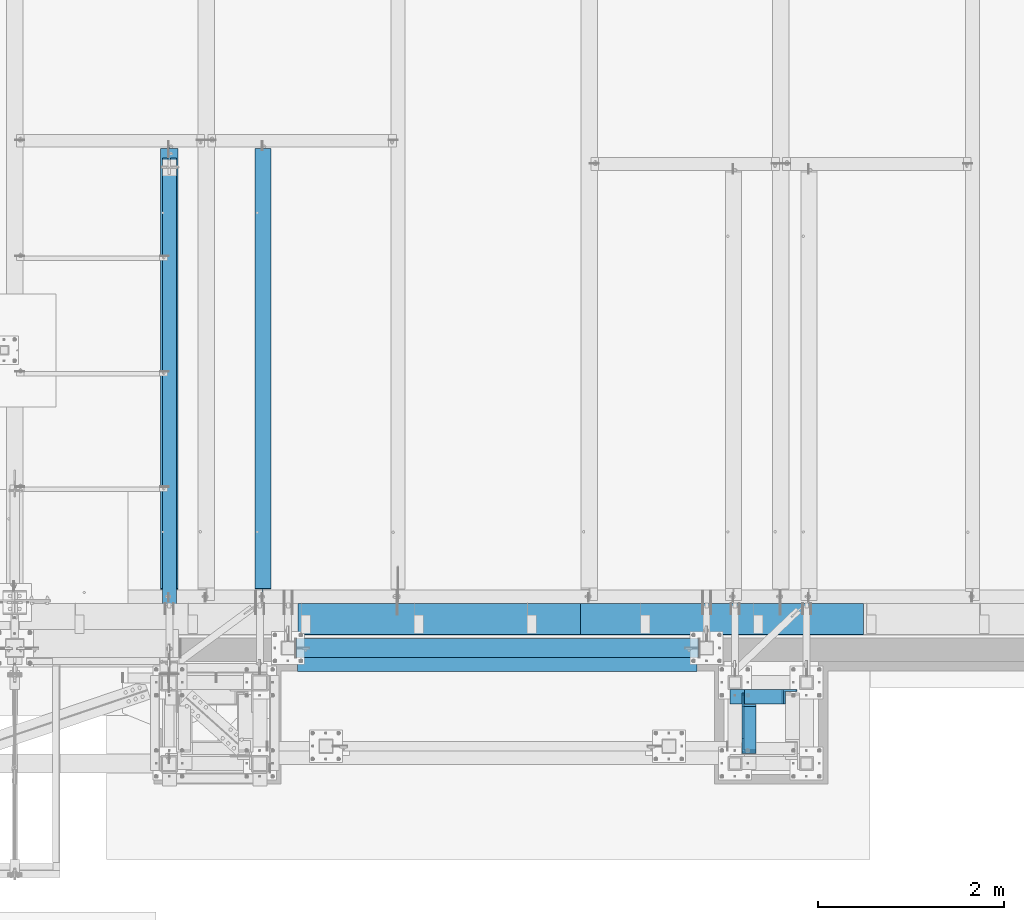
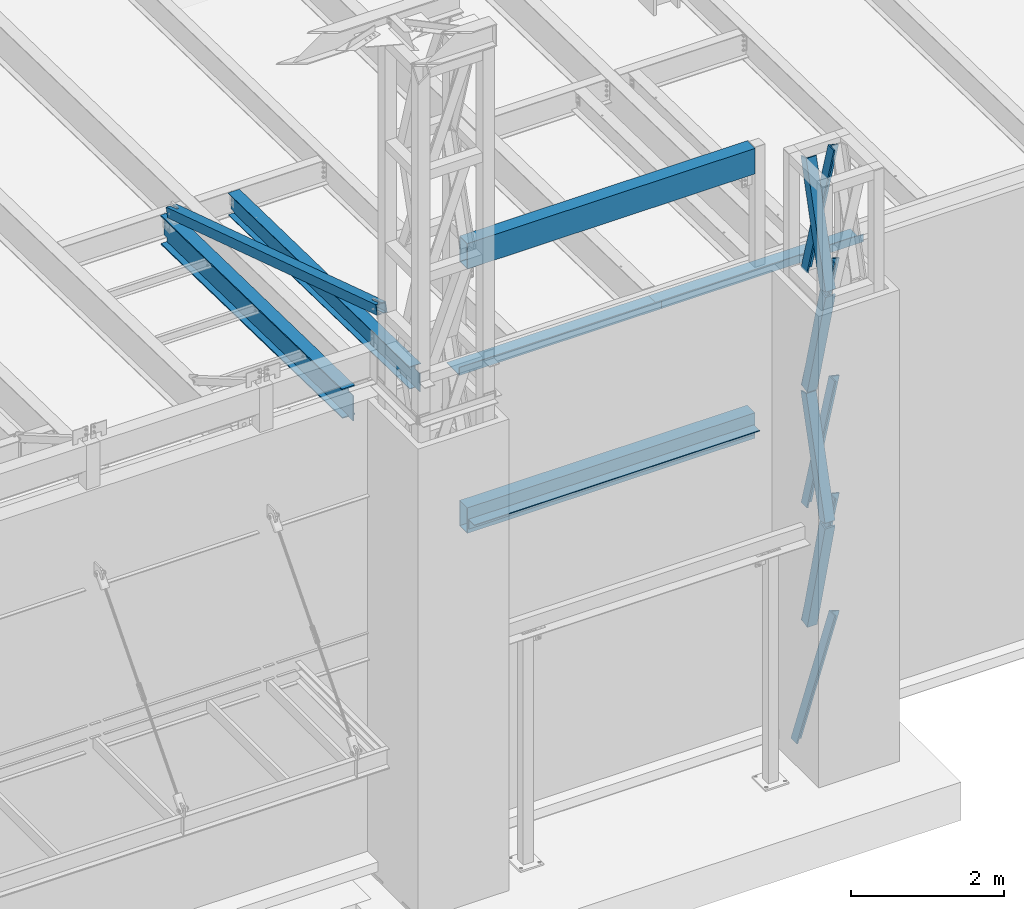
# One storey, part 1064 of 1763: 9 members, 8 beams, 7 elements without a shape of their own.
"""IFC2X3 building model written with IfcOpenShell, lengths in millimetres."""

from ifc_helpers import new_model, si_unit, frame, origin_with_axes, place, context, subcontext, project, spatial, faceted_brep, material, type_object, element, aggregate, save


model = new_model("IFC2X3")

# Units and contexts
model_context = context("Model", 3, precision=1e-05, world=origin_with_axes())
body_context = subcontext(model_context, "Body", "Model", "MODEL_VIEW")
ifc_project = project(units=[si_unit("LENGTHUNIT", "METRE", prefix="MILLI"), si_unit("AREAUNIT", "SQUARE_METRE"), si_unit("VOLUMEUNIT", "CUBIC_METRE"), si_unit("MASSUNIT", "GRAM", prefix="KILO"), si_unit("TIMEUNIT", "SECOND"), si_unit("PLANEANGLEUNIT", "RADIAN"), si_unit("SOLIDANGLEUNIT", "STERADIAN"), si_unit("THERMODYNAMICTEMPERATUREUNIT", "DEGREE_CELSIUS"), si_unit("LUMINOUSINTENSITYUNIT", "LUMEN")], contexts=[model_context])

# Site, building, storey
site_placement = place(None, origin_with_axes())
site = spatial("IfcSite", under=ifc_project, at=site_placement, CompositionType="ELEMENT")
building_placement = place(site_placement, origin_with_axes())
building = spatial("IfcBuilding", under=site, at=building_placement, Name="Undefined", CompositionType="ELEMENT")
storey_placement = place(building_placement, origin_with_axes())
storey = spatial("IfcBuildingStorey", under=building, at=storey_placement, Name="Undefined", CompositionType="ELEMENT", Elevation=0.0)

# Assembly, members
assembly_1_placement = place(storey_placement, origin_with_axes())
assembly_1 = element("IfcElementAssembly", 1, at=assembly_1_placement, inside=storey, Name="FRAME", AssemblyPlace="NOTDEFINED", PredefinedType="RIGID_FRAME")
ifc_material_1 = material(Name="STEEL/A36")
member_type = type_object("IfcMemberType", Name="L6X6X7/8", PredefinedType="NOTDEFINED")
member_1_placement = place(assembly_1_placement, frame((-41487.0960743807, -15268.1037197873, 12563.9140540722), z_axis=(0.0, 0.966292662023721, 0.25744609400632), x_axis=(0.0, 0.25744609400632, -0.966292662023721)))
member_1 = element("IfcMember", 2, at=member_1_placement, type_object=member_type, material=ifc_material_1, Name="V. BRACE", ObjectType="L6X6X7/8", context=body_context, shape_type="Brep", body=[
    faceted_brep([(9.09494701772928e-13, -76.2000000000007, -76.2000000000844), (9.09494701772928e-13, 76.2000000000007, -76.2000000000844), (1868.75344729561, 76.1999999999971, -76.1999999992731), (1868.75344729561, -76.1999999999971, -76.1999999992731), (1.81898940354586e-12, -76.2000000000007, -53.9750000000604), (1.81898940354586e-12, 53.9750000000004, -53.9750000000604), (0.0, 53.9750000000004, 76.2000000000771), (0.0, 76.2000000000007, 76.2000000000771), (1868.7534472956, -76.1999999999971, -53.9749999992673), (1868.7534472956, 53.9750000000058, -53.9749999992673), (1868.75344729555, 53.9750000000058, 76.2000000007865), (1868.75344729555, 76.1999999999971, 76.2000000007865)], [[[0, 1, 2, 3]], [[0, 4, 5, 6, 7, 1]], [[5, 4, 8, 9]], [[6, 5, 9, 10]], [[7, 6, 10, 11]], [[1, 7, 11, 2]], [[10, 9, 8, 3, 2, 11]], [[4, 0, 3, 8]]]),
])
member_2_placement = place(assembly_1_placement, frame((-41487.0960743773, -14763.9971201611, 14438.0001145442), z_axis=(0.0, 0.963857514375967, -0.266418265103921), x_axis=(0.0, -0.266418265103921, -0.963857514375967)))
member_2 = element("IfcMember", 3, at=member_2_placement, type_object=member_type, material=ifc_material_1, Name="V. BRACE", ObjectType="L6X6X7/8", context=body_context, shape_type="Brep", body=[
    faceted_brep([(9.09494701772928e-13, -76.2000000000007, -76.2000000000844), (9.09494701772928e-13, 76.2000000000007, -76.2000000000844), (1892.74960718638, 76.1999999999971, -76.2000000004191), (1892.74960718638, -76.1999999999971, -76.2000000004191), (1.81898940354586e-12, -76.2000000000007, -53.9750000000604), (1.81898940354586e-12, 53.9750000000004, -53.9750000000604), (0.0, 53.9750000000004, 76.2000000000771), (0.0, 76.2000000000007, 76.2000000000771), (1892.74960718638, -76.1999999999971, -53.9750000004096), (1892.74960718638, 53.9750000000058, -53.9750000004096), (1892.74960718641, 53.9750000000058, 76.1999999996406), (1892.74960718641, 76.1999999999971, 76.1999999996406)], [[[0, 1, 2, 3]], [[0, 4, 5, 6, 7, 1]], [[5, 4, 8, 9]], [[6, 5, 9, 10]], [[7, 6, 10, 11]], [[1, 7, 11, 2]], [[10, 9, 8, 3, 2, 11]], [[4, 0, 3, 8]]]),
])
member_3_placement = place(assembly_1_placement, frame((-41487.0960743875, -15255.7819813628, 8864.91422130301), z_axis=(0.0, 0.969515885272661, 0.24502846406891), x_axis=(0.0, 0.24502846406891, -0.969515885272661)))
member_3 = element("IfcMember", 4, at=member_3_placement, type_object=member_type, material=ifc_material_1, Name="V. BRACE", ObjectType="L6X6X7/8", context=body_context, shape_type="Brep", body=[
    faceted_brep([(9.09494701772928e-13, -76.2000000000007, -76.2000000000844), (9.09494701772928e-13, 76.2000000000007, -76.2000000000844), (1913.17175781412, 76.1999999999971, -76.1999999993586), (1913.17175781412, -76.1999999999971, -76.1999999993586), (1.81898940354586e-12, -76.2000000000007, -53.9750000000604), (1.81898940354586e-12, 53.9750000000004, -53.9750000000604), (0.0, 53.9750000000004, 76.2000000000771), (0.0, 76.2000000000007, 76.2000000000771), (1913.17175781411, -76.1999999999971, -53.9749999993746), (1913.17175781411, 53.9749999999985, -53.9749999993746), (1913.17175781408, 53.9749999999985, 76.2000000005337), (1913.17175781408, 76.1999999999971, 76.2000000005337)], [[[0, 1, 2, 3]], [[0, 4, 5, 6, 7, 1]], [[5, 4, 8, 9]], [[6, 5, 9, 10]], [[7, 6, 10, 11]], [[1, 7, 11, 2]], [[10, 9, 8, 3, 2, 11]], [[4, 0, 3, 8]]]),
])
member_4_placement = place(assembly_1_placement, frame((-41487.0960743841, -14763.9971201611, 10689.9126145442), z_axis=(0.0, 0.963857514375967, -0.266418265103921), x_axis=(0.0, -0.266418265103921, -0.963857514375967)))
member_4 = element("IfcMember", 5, at=member_4_placement, type_object=member_type, material=ifc_material_1, Name="V. BRACE", ObjectType="L6X6X7/8", context=body_context, shape_type="Brep", body=[
    faceted_brep([(9.09494701772928e-13, -76.2000000000007, -76.2000000000844), (9.09494701772928e-13, 76.2000000000007, -76.2000000000844), (1841.94960718806, 76.1999999999971, -76.2000000009866), (1841.94960718806, -76.1999999999971, -76.2000000009866), (1.81898940354586e-12, -76.2000000000007, -53.9750000000604), (1.81898940354586e-12, 53.9750000000004, -53.9750000000604), (0.0, 53.9750000000004, 76.2000000000771), (0.0, 76.2000000000007, 76.2000000000771), (1841.94960718807, -76.1999999999971, -53.9750000009735), (1841.94960718807, 53.9749999999985, -53.9750000009735), (1841.94960718814, 53.9749999999985, 76.199999999084), (1841.94960718814, 76.1999999999971, 76.199999999084)], [[[0, 1, 2, 3]], [[0, 4, 5, 6, 7, 1]], [[5, 4, 8, 9]], [[6, 5, 9, 10]], [[7, 6, 10, 11]], [[1, 7, 11, 2]], [[10, 9, 8, 3, 2, 11]], [[4, 0, 3, 8]]]),
])
member_5_placement = place(assembly_1_placement, frame((-41464.0220474146, -14731.9306029674, 10714.8312500472), z_axis=(0.0, -1.0, 0.0), x_axis=(0.218804753982199, 0.0, 0.975768660920604)))
member_5 = element("IfcMember", 6, at=member_5_placement, type_object=member_type, material=ifc_material_1, Name="V. BRACE", ObjectType="L6X6X7/8", context=body_context, shape_type="Brep", body=[
    faceted_brep([(9.09494701772928e-13, 76.2000000000007, -76.2000000000844), (0.0, 76.2000000000007, 76.2000000000771), (1920.5820240066, 76.2000000000007, 76.1999999998516), (1920.58202400652, 76.2000000000007, -76.2000000004628), (0.0, 53.9750000000004, 76.2000000000771), (1920.5820240066, 53.9750000000004, 76.1999999998516), (1.81898940354586e-12, 53.9750000000004, -53.9750000000604), (1920.58202400653, 53.9750000000004, -53.9750000004133), (1.81898940354586e-12, -76.2000000000007, -53.9750000000604), (1920.58202400653, -76.2000000000007, -53.9750000004133), (9.09494701772928e-13, -76.2000000000007, -76.2000000000844), (1920.58202400652, -76.2000000000007, -76.2000000004628)], [[[0, 1, 2, 3]], [[1, 4, 5, 2]], [[4, 6, 7, 5]], [[6, 8, 9, 7]], [[8, 10, 11, 9]], [[10, 0, 3, 11]], [[5, 7, 9, 11, 3, 2]], [[10, 8, 6, 4, 1, 0]]]),
])
member_6_placement = place(assembly_1_placement, frame((-41464.0220474111, -14731.9306029674, 8840.78750004715), z_axis=(0.0, -1.0, 0.0), x_axis=(0.218804753982199, 0.0, 0.975768660920604)))
member_6 = element("IfcMember", 7, at=member_6_placement, type_object=member_type, material=ifc_material_1, Name="V. BRACE", ObjectType="L6X6X7/8", context=body_context, shape_type="Brep", body=[
    faceted_brep([(9.09494701772928e-13, 76.2000000000007, -76.2000000000844), (0.0, 76.2000000000007, 76.2000000000771), (1920.5820240066, 76.2000000000007, 76.1999999998516), (1920.58202400652, 76.2000000000007, -76.2000000004628), (0.0, 53.9750000000004, 76.2000000000771), (1920.5820240066, 53.9750000000004, 76.1999999998516), (1.81898940354586e-12, 53.9750000000004, -53.9750000000604), (1920.58202400653, 53.9750000000004, -53.9750000004133), (1.81898940354586e-12, -76.2000000000007, -53.9750000000604), (1920.58202400653, -76.2000000000007, -53.9750000004133), (9.09494701772928e-13, -76.2000000000007, -76.2000000000844), (1920.58202400652, -76.2000000000007, -76.2000000004628)], [[[0, 1, 2, 3]], [[1, 4, 5, 2]], [[4, 6, 7, 5]], [[6, 8, 9, 7]], [[8, 10, 11, 9]], [[10, 0, 3, 11]], [[5, 7, 9, 11, 3, 2]], [[10, 8, 6, 4, 1, 0]]]),
])
member_7_placement = place(assembly_1_placement, frame((-41464.1695232919, -14731.9306029674, 12588.8750000574), z_axis=(0.0, -1.0, 0.0), x_axis=(0.219355453919122, 0.0, 0.975645009640256)))
member_7 = element("IfcMember", 8, at=member_7_placement, type_object=member_type, material=ifc_material_1, Name="V. BRACE", ObjectType="L6X6X7/8", context=body_context, shape_type="Brep", body=[
    faceted_brep([(9.09494701772928e-13, 76.2000000000007, -76.2000000000844), (0.0, 76.2000000000007, 76.2000000000771), (1858.18097968706, 76.1999999878753, 76.2000000000007), (1858.18097968706, 76.1999999878753, -76.2000000000007), (0.0, 53.9750000000004, 76.2000000000771), (1858.1809796871, 53.9749999877386, 76.2000000000007), (1.81898940354586e-12, 53.9750000000004, -53.9750000000604), (1858.1809796871, 53.9749999877386, -53.9750000000004), (1.81898940354586e-12, -76.2000000000007, -53.9750000000604), (1858.18097968729, -76.2000000130356, -53.9750000000004), (9.09494701772928e-13, -76.2000000000007, -76.2000000000844), (1858.18097968729, -76.2000000130356, -76.2000000000007)], [[[0, 1, 2, 3]], [[1, 4, 5, 2]], [[4, 6, 7, 5]], [[6, 8, 9, 7]], [[8, 10, 11, 9]], [[10, 0, 3, 11]], [[5, 7, 9, 11, 3, 2]], [[10, 8, 6, 4, 1, 0]]]),
])
member_8_placement = place(assembly_1_placement, frame((-41464.0220474077, -14731.9306029674, 6966.74375004715), z_axis=(0.0, -1.0, 0.0), x_axis=(0.218804753982199, 0.0, 0.975768660920604)))
member_8 = element("IfcMember", 9, at=member_8_placement, type_object=member_type, material=ifc_material_1, Name="V. BRACE", ObjectType="L6X6X7/8", context=body_context, shape_type="Brep", body=[
    faceted_brep([(9.09494701772928e-13, 76.2000000000007, -76.2000000000844), (0.0, 76.2000000000007, 76.2000000000771), (1920.5820240066, 76.2000000000007, 76.1999999998516), (1920.58202400652, 76.2000000000007, -76.2000000004628), (0.0, 53.9750000000004, 76.2000000000771), (1920.5820240066, 53.9750000000004, 76.1999999998516), (1.81898940354586e-12, 53.9750000000004, -53.9750000000604), (1920.58202400653, 53.9750000000004, -53.9750000004133), (1.81898940354586e-12, -76.2000000000007, -53.9750000000604), (1920.58202400653, -76.2000000000007, -53.9750000004133), (9.09494701772928e-13, -76.2000000000007, -76.2000000000844), (1920.58202400652, -76.2000000000007, -76.2000000004628)], [[[0, 1, 2, 3]], [[1, 4, 5, 2]], [[4, 6, 7, 5]], [[6, 8, 9, 7]], [[8, 10, 11, 9]], [[10, 0, 3, 11]], [[5, 7, 9, 11, 3, 2]], [[10, 8, 6, 4, 1, 0]]]),
])
member_9_placement = place(assembly_1_placement, frame((-41639.5634959182, -14731.9306029674, 5067.3), z_axis=(0.0, -1.0, 0.0), x_axis=(0.30006571093599, 0.0, 0.953918533796508)))
member_9 = element("IfcMember", 10, at=member_9_placement, type_object=member_type, material=ifc_material_1, Name="V. BRACE", ObjectType="L6X6X7/8", context=body_context, shape_type="Brep", body=[
    faceted_brep([(63.9100772377278, 76.1999999996478, -76.2000000000007), (63.9100772377278, 76.1999999996478, 76.2000000000007), (1991.20122200253, 76.1999999978143, 76.2000000000007), (1991.20122200253, 76.1999999978143, -76.2000000000007), (63.9100772377224, 53.9749999997293, 76.2000000000007), (1991.2012220025, 53.9749999978958, 76.2000000000007), (63.9100772377224, 53.9749999997293, -53.9750000000004), (1991.2012220025, 53.9749999978958, -53.9750000000004), (63.9100772376914, -76.1999999997788, -53.9750000000004), (1991.20122200235, -76.2000000016124, -53.9750000000004), (63.9100772376914, -76.1999999997788, -76.2000000000007), (1991.20122200235, -76.2000000016124, -76.2000000000007)], [[[0, 1, 2, 3]], [[1, 4, 5, 2]], [[4, 6, 7, 5]], [[6, 8, 9, 7]], [[8, 10, 11, 9]], [[10, 0, 3, 11]], [[5, 7, 9, 11, 3, 2]], [[10, 8, 6, 4, 1, 0]]]),
])
aggregate(assembly_1, [member_1, member_2, member_3, member_4, member_5, member_6, member_7, member_8, member_9])

# Assembly, beam
assembly_2_placement = place(storey_placement, origin_with_axes())
assembly_2 = element("IfcElementAssembly", 11, at=assembly_2_placement, inside=storey, Name="V. BRACE", AssemblyPlace="NOTDEFINED", PredefinedType="RIGID_FRAME")
ifc_material_2 = material()
beam_type_1 = type_object("IfcBeamType", Name="HSS6X6X1/2", PredefinedType="NOTDEFINED")
beam_1_placement = place(assembly_2_placement, frame((-47735.5634959181, -14490.7023151462, 14001.7707184966), z_axis=(0.0, 0.306784151144964, 0.951779115449726), x_axis=(0.0, 0.951779115449727, -0.306784151144964)))
beam_1 = element("IfcBeam", 12, at=beam_1_placement, type_object=beam_type_1, material=ifc_material_2, Name="V. BRACE", ObjectType="HSS6X6X1/2", context=body_context, shape_type="Brep", body=[
    faceted_brep([(64.5916172349789, 14.2874999999985, 76.2000000000317), (64.5916172349789, 14.2874999999985, 63.5000000000218), (274.141621753359, 14.2874999999985, 63.4999999999272), (274.141621753362, 14.2874999999985, 76.1999999999389), (274.141621753362, -14.2874988555923, 76.1999999999389), (274.141621753359, -14.2874988555923, 63.4999999999272), (64.5916172349789, -14.2874988555923, 63.5000000000218), (64.5916172349789, -14.2874988555923, 76.2000000000317), (64.5916172349753, 14.2874999999985, -63.5000000000764), (64.5916172349753, 14.2874999999985, -76.2000000000844), (274.141621753297, 14.2874999999985, -76.200000000179), (274.141621753301, 14.2874999999985, -63.500000000171), (274.141621753301, -14.2874988555923, -63.500000000171), (274.141621753297, -14.2874988555923, -76.200000000179), (64.5916172349753, -14.2874988555923, -76.2000000000844), (64.5916172349753, -14.2874988555923, -63.5000000000764), (64.5916172349789, 63.5, 63.5000000000218), (64.5916172349753, 63.5, -63.5000000000764), (5820.2575051603, 63.5, -63.5000000026248), (5820.2575051603, 63.5, 63.4999999974752), (64.5916172349753, 76.1999999999971, -76.2000000000844), (5820.2575051603, 76.1999999999971, -76.2000000026346), (5820.2575051603, 14.2874999409978, -76.2000000026346), (5629.75750516893, 14.2874984164446, -76.200000002551), (5629.75750539753, -14.2875004392699, -76.200000002551), (5820.2575051603, -14.287498914593, -76.2000000026346), (5820.2575051603, -76.1999999999971, -76.2000000026346), (64.5916172349753, -76.1999999999971, -76.2000000000844), (5820.2575051603, 14.2874999480191, -63.5000000026248), (5629.75750516893, 14.2874984234659, -63.5000000025411), (5629.75750539754, -14.2875004322486, -63.5000000025411), (5820.25750516775, -14.2874989075717, -63.5000000026266), (64.5916172349753, -63.5, -63.5000000000764), (64.5916172349789, -63.5, 63.5000000000218), (5820.2575051603, -63.5, 63.4999999974752), (5820.2575051603, -63.5, -63.5000000026248), (5629.7575053976, -14.2875003549998, 76.1999999975669), (5629.75750539759, -14.2875003620211, 63.4999999975589), (5629.75750516899, 14.2874984936934, 63.4999999975589), (5629.75750516899, 14.2874985007147, 76.1999999975687), (5820.25750516781, -14.2874988303229, 76.1999999974832), (5820.2575051603, -14.2874988373442, 63.4999999974752), (5820.2575051603, -76.1999999999971, 76.1999999974851), (64.5916172349789, -76.1999999999971, 76.2000000000317), (5820.2575051603, 14.2875000182466, 63.4999999974752), (5820.2575051603, 14.2875000252679, 76.1999999974851), (5820.2575051603, 76.1999999999971, 76.1999999974851), (64.5916172349789, 76.1999999999971, 76.2000000000317)], [[[0, 1, 2, 3]], [[4, 5, 6, 7]], [[3, 2, 5, 4]], [[8, 9, 10, 11]], [[12, 13, 14, 15]], [[11, 10, 13, 12]], [[16, 17, 18, 19]], [[9, 20, 21, 22, 23, 24, 25, 26, 27, 14, 13, 10]], [[28, 29, 23, 22]], [[30, 24, 23, 29]], [[31, 25, 24, 30]], [[32, 33, 34, 35]], [[36, 37, 38, 39]], [[40, 41, 37, 36]], [[42, 26, 25, 31, 35, 34, 41, 40]], [[43, 27, 26, 42]], [[33, 32, 15, 14, 27, 43, 7, 6]], [[1, 16, 19, 44, 38, 37, 41, 34, 33, 6, 5, 2]], [[45, 39, 38, 44]], [[19, 18, 28, 22, 21, 46, 45, 44]], [[20, 47, 46, 21]], [[43, 42, 40, 36, 39, 45, 46, 47, 0, 3, 4, 7]], [[47, 20, 9, 8, 17, 16, 1, 0]], [[32, 35, 31, 30, 29, 28, 18, 17, 8, 11, 12, 15]]]),
])
aggregate(assembly_2, [beam_1])

assembly_3_placement = place(storey_placement, origin_with_axes())
assembly_3 = element("IfcElementAssembly", 13, at=assembly_3_placement, inside=storey, Name="BEAM", AssemblyPlace="NOTDEFINED", PredefinedType="RIGID_FRAME")
beam_type_2 = type_object("IfcBeamType", Name="HSS16X8X1/4", PredefinedType="NOTDEFINED")
beam_2_placement = place(assembly_3_placement, frame((-46380.2555979689, -14208.1264769908, 14262.1), z_axis=(0.0, 0.0, 1.0), x_axis=(1.0, 0.0, 0.0)))
beam_2 = element("IfcBeam", 14, at=beam_2_placement, type_object=beam_type_2, material=ifc_material_2, Name="BEAM", ObjectType="HSS16X8X1/4", context=body_context, shape_type="Brep", body=[
    faceted_brep([(9.52500000002328, 95.25, -196.85), (9.52500000002328, -95.25, -196.85), (4349.75034179688, -95.25, -196.85), (4349.75034179688, 95.25, -196.85), (9.52500000002328, -95.25, 196.85), (4349.75034179688, -95.25, 196.85), (9.52500000002328, 95.25, 196.85), (4349.75034179688, 95.25, 196.85), (9.52500000002328, 101.6, -203.200000000001), (9.52500000002328, 101.6, 203.200000000001), (4349.75034179688, 101.6, 203.200000000001), (4349.75034179688, 101.6, -203.200000000001), (9.52500000002328, -101.6, 203.200000000001), (4349.75034179688, -101.6, 203.200000000001), (9.52500000002328, -101.6, -203.200000000001), (4349.75034179688, -101.6, -203.200000000001)], [[[0, 1, 2, 3]], [[1, 4, 5, 2]], [[4, 6, 7, 5]], [[6, 0, 3, 7]], [[8, 9, 10, 11]], [[9, 12, 13, 10]], [[12, 14, 15, 13]], [[14, 8, 11, 15]], [[13, 15, 11, 10], [5, 7, 3, 2]], [[14, 12, 9, 8], [6, 4, 1, 0]]]),
])
aggregate(assembly_3, [beam_2])

assembly_4_placement = place(storey_placement, origin_with_axes())
assembly_4 = element("IfcElementAssembly", 15, at=assembly_4_placement, inside=storey, Name="BEAM", AssemblyPlace="NOTDEFINED", PredefinedType="RIGID_FRAME")
beam_3_placement = place(assembly_4_placement, frame((-46380.2555979689, -14208.1264769908, 10045.7), z_axis=(0.0, 0.0, 1.0), x_axis=(1.0, 0.0, 0.0)))
beam_3 = element("IfcBeam", 16, at=beam_3_placement, type_object=beam_type_2, material=ifc_material_2, Name="BEAM", ObjectType="HSS16X8X1/4", context=body_context, shape_type="Brep", body=[
    faceted_brep([(9.52500000002328, 95.25, -196.85), (9.52500000002328, -95.25, -196.85), (4349.75034179688, -95.25, -196.85), (4349.75034179688, 95.25, -196.85), (9.52500000002328, -95.25, 196.85), (4349.75034179688, -95.25, 196.85), (9.52500000002328, 95.25, 196.85), (4349.75034179688, 95.25, 196.85), (9.52500000002328, 101.6, -203.200000000001), (9.52500000002328, 101.6, 203.200000000001), (4349.75034179688, 101.6, 203.200000000001), (4349.75034179688, 101.6, -203.200000000001), (9.52500000002328, -101.6, 203.200000000001), (4349.75034179688, -101.6, 203.200000000001), (9.52500000002328, -101.6, -203.200000000001), (4349.75034179688, -101.6, -203.200000000001)], [[[0, 1, 2, 3]], [[1, 4, 5, 2]], [[4, 6, 7, 5]], [[6, 0, 3, 7]], [[8, 9, 10, 11]], [[9, 12, 13, 10]], [[12, 14, 15, 13]], [[14, 8, 11, 15]], [[13, 15, 11, 10], [5, 7, 3, 2]], [[14, 12, 9, 8], [6, 4, 1, 0]]]),
])

assembly_5_placement = place(storey_placement, origin_with_axes())
assembly_5 = element("IfcElementAssembly", 17, at=assembly_5_placement, inside=storey, Name="BEAM", AssemblyPlace="NOTDEFINED", PredefinedType="RIGID_FRAME")
ifc_material_3 = material(Name="STEEL/A992")
beam_type_3 = type_object("IfcBeamType", Name="W14X30", PredefinedType="NOTDEFINED")
beam_4_placement = place(assembly_5_placement, frame((-46728.1801308412, -13719.6833830648, 12028.5259948837), z_axis=(0.0, 0.0209013539966291, 0.999781542838788), x_axis=(0.0, 0.999781542776098, -0.0209013569953182)))
beam_4 = element("IfcBeam", 18, at=beam_4_placement, type_object=beam_type_3, material=ifc_material_3, Name="BEAM", ObjectType="W14X30", context=body_context, shape_type="Brep", body=[
    faceted_brep([(27.8111344336157, -3.47519961935177, -166.687500000151), (28.0102633315673, -3.47489117072837, -176.21250000016), (151.32641336501, -3.4748459137918, -176.212500000207), (151.326413365119, -3.4751542893282, -166.687500000198), (151.326443550766, -85.7249999999985, -166.687500000198), (151.326443550764, -85.7249999999985, -176.212500000205), (4895.86394307292, 85.7249999999985, -166.687500002026), (4895.86394307291, 85.7249999999985, -176.212500002035), (151.326380555069, 85.7249999999985, -176.212500000205), (151.326380555074, 85.7249999999985, -166.6875000002), (151.326410740694, 3.47515414370719, -176.212500000209), (151.326410740803, 3.4748457681635, -166.6875000002), (28.0102633315673, 3.47510888676334, -176.21250000016), (27.8111344336157, 3.47480043813994, -166.687500000151), (27.8111344336157, 3.17500000000291, -166.687500000151), (4895.86394307292, 3.17500000000291, -166.687500002026), (4962.69925695048, -3.17500000000291, 144.202501667341), (4962.69925695048, 3.17500000000291, 144.202501667341), (4908.56394288234, 3.17500000000291, 144.202501667363), (4908.56394288234, -3.17500000000291, 144.202501667363), (4903.70386336428, 3.17500000000291, 145.169231589955), (4903.70386336428, -3.17500000000291, 145.169231589955), (4899.58368689612, 3.17500000000291, 147.922245490441), (4899.58368689612, -3.17500000000291, 147.922245490441), (4896.83067299563, 3.17500000000291, 152.042421958608), (4896.83067299563, -3.17500000000291, 152.042421958608), (4895.86394307305, 3.17500000000291, 156.902501476665), (4895.86394307305, -3.17500000000291, 156.902501476665), (151.326378720316, 3.17500000000291, 166.687500000082), (151.326378720316, 85.7249999999985, 166.687500000082), (4895.86394307305, 85.7249999999985, 166.687499998254), (4895.86394307305, 3.17500000000291, 166.687499998254), (151.326378720321, -85.7249999999985, 176.212500000091), (151.326378720316, -85.7249999999985, 166.687500000082), (4895.86394307305, -85.7249999999985, 166.687499998254), (4895.86394307305, -85.7249999999985, 176.212499998263), (151.326378720321, 85.7249999999985, 176.212500000091), (4895.86394307305, 85.7249999999985, 176.212499998263), (4895.86394307305, -3.17500000000291, 166.687499998254), (151.326378720316, -3.17500000000291, 166.687500000082), (151.326378720303, 3.17500000000291, 131.502497673067), (151.326378720303, -3.17500000000291, 131.502497673067), (150.359648797712, 3.17500000000291, 126.642418155008), (150.359648797712, -3.17500000000291, 126.642418155008), (147.606634897225, 3.17500000000291, 122.522241686846), (147.606634897225, -3.17500000000291, 122.522241686846), (143.486458429059, 3.17500000000291, 119.769227786361), (143.486458429059, -3.17500000000291, 119.769227786361), (138.626378911002, 3.17500000000291, 118.802497863775), (138.626378911002, -3.17500000000291, 118.802497863775), (21.8427030791936, 3.17500000000291, 118.802497863819), (21.8427030791936, -3.17500000000291, 118.802497863819), (27.8111344336157, -3.17500000000291, -166.687500000151), (4895.86394307292, -3.17500000000291, -166.687500002026), (4895.86394307292, -3.17500000000291, -157.422499821279), (4896.83067299552, -3.17500000000291, -152.562420303222), (4899.583686896, -3.17500000000291, -148.442243835058), (4903.70386336417, -3.17500000000291, -145.689229934575), (4908.56394288223, -3.17500000000291, -144.722500011987), (4968.73950022345, -3.17500000000291, -144.722500012009), (4968.73950022345, 3.17500000000291, -144.722500012009), (4903.70386336417, 3.17500000000291, -145.689229934575), (4899.583686896, 3.17500000000291, -148.442243835058), (4896.83067299552, 3.17500000000291, -152.562420303222), (4895.86394307292, 3.17500000000291, -157.422499821279), (4908.56394288223, 3.17500000000291, -144.722500011987), (4895.86394307292, -85.7249999999985, -166.687500002026), (4895.86394307291, -85.7249999999985, -176.212500002035)], [[[0, 1, 2, 3]], [[4, 3, 2, 5]], [[6, 7, 8, 9]], [[9, 8, 10, 11]], [[11, 10, 12, 13]], [[14, 15, 6, 9, 11, 13]], [[16, 17, 18, 19]], [[19, 18, 20, 21]], [[21, 20, 22, 23]], [[23, 22, 24, 25]], [[25, 24, 26, 27]], [[28, 29, 30, 31]], [[32, 33, 34, 35]], [[36, 32, 35, 37]], [[29, 36, 37, 30]], [[35, 34, 38, 27, 26, 31, 30, 37]], [[33, 39, 38, 34]], [[32, 36, 29, 28, 40, 41, 39, 33]], [[41, 40, 42, 43]], [[43, 42, 44, 45]], [[45, 44, 46, 47]], [[47, 46, 48, 49]], [[49, 48, 50, 51]], [[16, 19, 21, 23, 25, 27, 38, 39, 41, 43, 45, 47, 49, 51, 52, 53, 54, 55, 56, 57, 58, 59]], [[17, 16, 59, 60]], [[61, 62, 63, 64, 15, 14, 50, 48, 46, 44, 42, 40, 28, 31, 26, 24, 22, 20, 18, 17, 60, 65]], [[59, 58, 65, 60]], [[57, 61, 65, 58]], [[56, 62, 61, 57]], [[55, 63, 62, 56]], [[54, 64, 63, 55]], [[53, 66, 67, 7, 6, 15, 64, 54]], [[67, 66, 4, 5]], [[1, 12, 10, 8, 7, 67, 5, 2]], [[52, 51, 50, 14, 13, 12, 1, 0]], [[66, 53, 52, 0, 3, 4]]]),
])
aggregate(assembly_5, [beam_4])

# Beam
beam_type_4 = type_object("IfcBeamType", Name="L6X6X3/8", PredefinedType="NOTDEFINED")
beam_5_placement = place(assembly_4_placement, frame((-46354.8555979689, -14385.9264769908, 9986.9625), z_axis=(0.0, -1.0, 0.0), x_axis=(1.0, 0.0, 0.0)))
beam_5 = element("IfcBeam", 19, at=beam_5_placement, type_object=beam_type_4, material=ifc_material_1, Name="ANGLE", ObjectType="L6X6X3/8", context=body_context, shape_type="Brep", body=[
    faceted_brep([(9.09494701772928e-13, 76.2000000000007, -76.2000000000844), (0.0, 76.2000000000007, 76.2000000000771), (4308.47534179688, 76.2000000000007, 76.2000000000007), (4308.47534179688, 76.2000000000007, -76.2000000000007), (0.0, 66.6749999999993, 76.2000000000007), (4308.47534179688, 66.6749999999993, 76.2000000000007), (0.0, 66.6749999999993, -66.6749999999993), (4308.47534179688, 66.6749999999993, -66.6749999999993), (0.0, -76.2000000000007, -66.6749999999993), (4308.47534179688, -76.2000000000007, -66.6749999999993), (9.09494701772928e-13, -76.2000000000007, -76.2000000000844), (4308.47534179688, -76.2000000000007, -76.2000000000007)], [[[0, 1, 2, 3]], [[1, 4, 5, 2]], [[4, 6, 7, 5]], [[6, 8, 9, 7]], [[8, 10, 11, 9]], [[10, 0, 3, 11]], [[5, 7, 9, 11, 3, 2]], [[10, 8, 6, 4, 1, 0]]]),
])

aggregate(assembly_4, [beam_5, beam_3])

# Assembly, beams
assembly_6_placement = place(storey_placement, origin_with_axes())
assembly_6 = element("IfcElementAssembly", 20, at=assembly_6_placement, inside=storey, Name="BEAM", AssemblyPlace="NOTDEFINED", PredefinedType="RIGID_FRAME")
beam_type_5 = type_object("IfcBeamType", PredefinedType="NOTDEFINED")
beam_6_placement = place(assembly_6_placement, frame((-41779.2622736984, -13728.6998186171, 12207.875), z_axis=(-1.0, 0.0, 0.0), x_axis=(0.0, -1.0, 0.0)))
beam_6 = element("IfcBeam", 21, at=beam_6_placement, type_object=beam_type_5, material=ifc_material_1, Name="BENT_PLATE", context=body_context, shape_type="Brep", body=[
    faceted_brep([(0.0, -3.17499999999927, -1523.99999999999), (0.0, -3.17499999999927, 1524.0), (0.0, 3.17499999999927, 1524.0), (0.0, 3.17499999999927, -1523.99999999999), (330.200016784669, 3.17499999999927, 1524.0), (330.200016784669, 3.17499999999927, -1524.0), (336.550018310547, -3.17499999999927, -1524.0), (336.550018310547, -3.17499999999927, 1524.0), (330.19998779297, 123.824998474123, 1524.0), (330.19998779297, 123.824998474123, -1524.0), (336.549987792969, 123.825000000001, 1524.0), (336.549987792969, 123.825000000001, -1524.0)], [[[0, 1, 2, 3]], [[3, 2, 4, 5]], [[1, 0, 6, 7]], [[5, 4, 8, 9]], [[4, 2, 1, 7, 10, 8]], [[7, 6, 11, 10]], [[6, 0, 3, 5, 9, 11]], [[10, 11, 9, 8]]]),
])
beam_7_placement = place(assembly_6_placement, frame((-44827.2622736984, -13728.6998186171, 12207.875), z_axis=(-1.0, 0.0, 0.0), x_axis=(0.0, -1.0, 0.0)))
beam_7 = element("IfcBeam", 22, at=beam_7_placement, type_object=beam_type_5, material=ifc_material_1, Name="BENT_PLATE", context=body_context, shape_type="Brep", body=[
    faceted_brep([(0.0, -3.17499999999927, -1523.99999999999), (0.0, -3.17499999999927, 1524.0), (0.0, 3.17499999999927, 1524.0), (0.0, 3.17499999999927, -1523.99999999999), (330.200016784669, 3.17499999999927, 1524.0), (330.200016784669, 3.17499999999927, -1524.0), (336.550018310547, -3.17499999999927, -1524.0), (336.550018310547, -3.17499999999927, 1524.0), (330.19998779297, 123.824998474123, 1524.0), (330.19998779297, 123.824998474123, -1524.0), (336.549987792969, 123.825000000001, 1524.0), (336.549987792969, 123.825000000001, -1524.0)], [[[0, 1, 2, 3]], [[3, 2, 4, 5]], [[1, 0, 6, 7]], [[5, 4, 8, 9]], [[4, 2, 1, 7, 10, 8]], [[7, 6, 11, 10]], [[6, 0, 3, 5, 9, 11]], [[10, 11, 9, 8]]]),
])
aggregate(assembly_6, [beam_6, beam_7])

# Assembly, beam
assembly_7_placement = place(storey_placement, origin_with_axes())
assembly_7 = element("IfcElementAssembly", 23, at=assembly_7_placement, inside=storey, Name="BEAM", AssemblyPlace="NOTDEFINED", PredefinedType="RIGID_FRAME")
beam_type_6 = type_object("IfcBeamType", Name="W18X60", PredefinedType="NOTDEFINED")
beam_8_placement = place(assembly_7_placement, frame((-47735.5634959181, -13720.8447145728, 11972.9756329103), z_axis=(0.0, 0.0209013539966291, 0.999781542838788), x_axis=(0.0, 0.999781542776098, -0.0209013569953182)))
beam_8 = element("IfcBeam", 24, at=beam_8_placement, type_object=beam_type_6, material=ifc_material_3, Name="BEAM", ObjectType="W18X60", context=body_context, shape_type="Brep", body=[
    faceted_brep([(29.968364187931, -5.85664649438695, -214.312500000193), (30.3334338341774, -5.85594176362792, -231.775000000207), (152.488004824314, -5.85589473412256, -231.775000000254), (152.488004824587, -5.85659932430281, -214.312500000238), (152.488039241056, -95.25, -214.31250000024), (152.488039241051, -95.25, -231.775000000254), (4897.02552833743, 95.25, -214.312500002068), (4897.02552833742, 95.25, -231.775000002082), (152.487965908522, 95.25, -231.775000000254), (152.487965908527, 95.25, -214.31250000024), (152.488000325198, 5.85659916265286, -231.775000000254), (152.488000325473, 5.85589457247261, -214.31250000024), (30.3334338341774, 5.85655213306018, -231.775000000207), (29.968364187931, 5.85584740230115, -214.312500000193), (29.968364187931, 5.55625000000146, -214.312500000193), (4897.02552833743, 5.55625000000146, -214.312500002068), (4962.69925697698, -5.55625000000146, 199.765001667532), (4962.69925697698, 5.55625000000146, 199.765001667532), (4909.72552814689, 5.55625000000146, 199.765001667551), (4909.72552814689, -5.55625000000146, 199.765001667551), (4904.86544862883, 5.55625000000146, 200.731731590144), (4904.86544862883, -5.55625000000146, 200.731731590144), (4900.74527216067, 5.55625000000146, 203.48474549063), (4900.74527216067, -5.55625000000146, 203.48474549063), (4897.99225826018, 5.55625000000146, 207.604921958797), (4897.99225826018, -5.55625000000146, 207.604921958797), (4897.0255283376, 5.55625000000146, 212.465001476854), (4897.0255283376, -5.55625000000146, 212.465001476854), (4897.0255283376, -95.25, 231.77499999831), (4897.0255283376, -95.25, 214.312499998296), (4897.0255283376, -5.55625000000146, 214.312499998296), (4897.0255283376, 5.55625000000146, 214.312499998296), (4897.0255283376, 95.25, 214.312499998296), (4897.0255283376, 95.25, 231.77499999831), (152.48796398487, 5.55625000000146, 214.312500000124), (152.48796398487, 95.25, 214.312500000124), (152.487963984877, 95.25, 231.775000000138), (152.487963984877, -95.25, 231.775000000138), (152.48796398487, -95.25, 214.312500000124), (152.48796398487, -5.55625000000146, 214.312500000124), (152.48796398486, 5.55625000000146, 187.064997673235), (152.48796398486, -5.55625000000146, 187.064997673235), (151.521234062267, 5.55625000000146, 182.204918155177), (151.521234062267, -5.55625000000146, 182.204918155177), (148.768220161781, 5.55625000000146, 178.084741687013), (148.768220161781, -5.55625000000146, 178.084741687013), (144.648043693614, 5.55625000000146, 175.331727786528), (144.648043693614, -5.55625000000146, 175.331727786528), (139.787964175559, 5.55625000000146, 174.364997863942), (139.787964175559, -5.55625000000146, 174.364997863942), (21.8427031056981, 5.55625000000146, 174.364997863986), (21.8427031056981, -5.55625000000146, 174.364997863986), (29.968364187931, -5.55625000000146, -214.312500000193), (4897.02552833743, -5.55625000000146, -214.312500002068), (4897.02552833745, -5.55625000000146, -162.184999821244), (4897.99225826004, -5.55625000000146, -157.324920303186), (4900.74527216053, -5.55625000000146, -153.204743835026), (4904.8654486287, -5.55625000000146, -150.451729934541), (4909.72552814675, -5.55625000000146, -149.485000011951), (4970.00064993699, -5.55625000000146, -149.485000011975), (4970.00064993699, 5.55625000000146, -149.485000011975), (4904.8654486287, 5.55625000000146, -150.451729934541), (4900.74527216053, 5.55625000000146, -153.204743835026), (4897.99225826004, 5.55625000000146, -157.324920303186), (4897.02552833745, 5.55625000000146, -162.184999821244), (4909.72552814675, 5.55625000000146, -149.485000011951), (4897.02552833743, -95.25, -214.312500002068), (4897.02552833742, -95.25, -231.775000002082)], [[[0, 1, 2, 3]], [[4, 3, 2, 5]], [[6, 7, 8, 9]], [[9, 8, 10, 11]], [[11, 10, 12, 13]], [[14, 15, 6, 9, 11, 13]], [[16, 17, 18, 19]], [[19, 18, 20, 21]], [[21, 20, 22, 23]], [[23, 22, 24, 25]], [[25, 24, 26, 27]], [[28, 29, 30, 27, 26, 31, 32, 33]], [[32, 31, 34, 35]], [[33, 32, 35, 36]], [[28, 33, 36, 37]], [[29, 28, 37, 38]], [[30, 29, 38, 39]], [[37, 36, 35, 34, 40, 41, 39, 38]], [[41, 40, 42, 43]], [[43, 42, 44, 45]], [[45, 44, 46, 47]], [[47, 46, 48, 49]], [[49, 48, 50, 51]], [[16, 19, 21, 23, 25, 27, 30, 39, 41, 43, 45, 47, 49, 51, 52, 53, 54, 55, 56, 57, 58, 59]], [[17, 16, 59, 60]], [[61, 62, 63, 64, 15, 14, 50, 48, 46, 44, 42, 40, 34, 31, 26, 24, 22, 20, 18, 17, 60, 65]], [[59, 58, 65, 60]], [[57, 61, 65, 58]], [[56, 62, 61, 57]], [[55, 63, 62, 56]], [[54, 64, 63, 55]], [[53, 66, 67, 7, 6, 15, 64, 54]], [[67, 66, 4, 5]], [[1, 12, 10, 8, 7, 67, 5, 2]], [[52, 51, 50, 14, 13, 12, 1, 0]], [[66, 53, 52, 0, 3, 4]]]),
])
aggregate(assembly_7, [beam_8])

save(model, "model.ifc")
